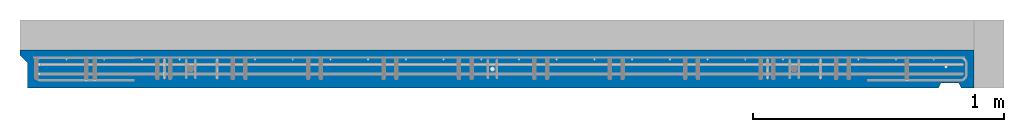
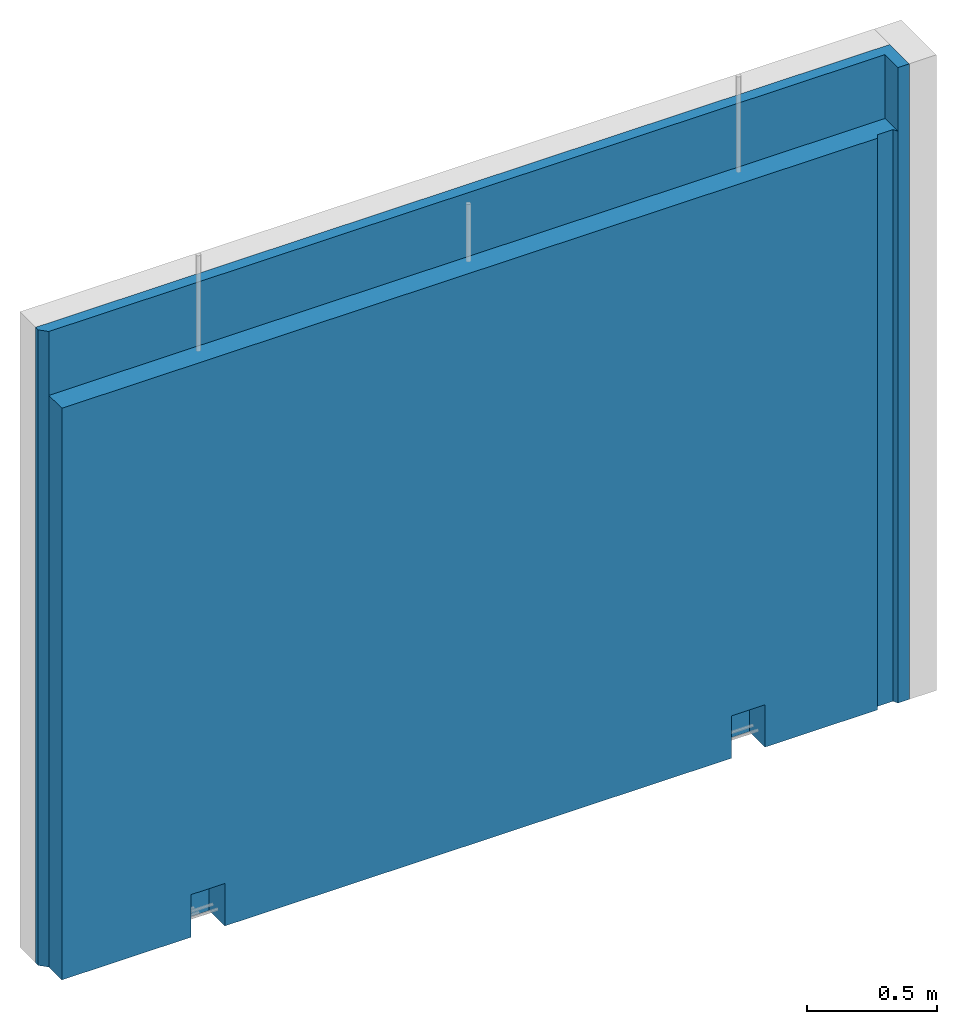
# One storey, part 9 of 9: 1 wall, 1 element without a shape of its own.
"""IFC2X3 building model written with IfcOpenShell, lengths in millimetres."""

from ifc_helpers import new_model, si_unit, frame, origin_with_axes, place, context, subcontext, project, spatial, faceted_brep, material, type_object, element, aggregate, save


model = new_model("IFC2X3")

# Units and contexts
model_context = context("Model", 3, precision=1e-05, world=origin_with_axes())
body_context = subcontext(model_context, "Body", "Model", "MODEL_VIEW")
ifc_project = project(units=[si_unit("LENGTHUNIT", "METRE", prefix="MILLI"), si_unit("AREAUNIT", "SQUARE_METRE"), si_unit("VOLUMEUNIT", "CUBIC_METRE"), si_unit("MASSUNIT", "GRAM", prefix="KILO"), si_unit("TIMEUNIT", "SECOND"), si_unit("PLANEANGLEUNIT", "RADIAN"), si_unit("SOLIDANGLEUNIT", "STERADIAN"), si_unit("THERMODYNAMICTEMPERATUREUNIT", "DEGREE_CELSIUS"), si_unit("LUMINOUSINTENSITYUNIT", "LUMEN")], contexts=[model_context])

# Site, building, storey
site_placement = place(None, origin_with_axes())
site = spatial("IfcSite", under=ifc_project, at=site_placement, CompositionType="ELEMENT")
building_placement = place(site_placement, origin_with_axes())
building = spatial("IfcBuilding", under=site, at=building_placement, Name="1", CompositionType="ELEMENT")
storey_placement = place(building_placement, origin_with_axes())
storey = spatial("IfcBuildingStorey", under=building, at=storey_placement, Name="1. kerros", CompositionType="ELEMENT", Elevation=0.0)

# Assembly, wall
assembly_placement = place(storey_placement, origin_with_axes())
assembly = element("IfcElementAssembly", 1, at=assembly_placement, inside=storey, AssemblyPlace="NOTDEFINED", PredefinedType="REINFORCEMENT_UNIT")
ifc_material = material(Name="CONCRETE/C30/37")
wall_type = type_object("IfcWallType", Name="2985X150", PredefinedType="NOTDEFINED")
wall_placement = place(assembly_placement, frame((41470.0022627602, 6575.00033187657, 1492.49992151562), z_axis=(0.0, 0.0, 1.0), x_axis=(0.999999999544916, -3.01690000137153e-05, 0.0)))
wall = element("IfcWall", 2, at=wall_placement, type_object=wall_type, material=ifc_material, ObjectType="2985X150", context=body_context, shape_type="Brep", body=[
    faceted_brep([(3654.40125343294, -75.0000001560766, 1192.49999998025), (3654.40125343294, -75.0, -1492.5), (3664.40125343294, -54.9932071461599, -1492.49999999915), (3664.40125343294, -54.9932071461599, 1192.49999998025), (3734.40125343294, -54.9932071461608, -1492.49999999915), (3734.40125343294, -54.9932071461608, 1192.49999998025), (3744.40125343294, -74.9932071458334, 1192.49999998025), (3744.40125343294, -75.0000000000009, -1492.5), (3154.07930080994, 45.0450785005714, -1492.51090734813), (3154.07930080994, 45.0450785005714, -1343.32355724257), (3004.07930079172, 45.0452070505726, -1343.32355724257), (3004.07930079172, 45.0452070505726, -1492.51090734732), (3154.07919796995, -74.9999999999991, -1492.5), (3154.07919796994, -74.954921499384, -1293.32355708434), (3004.07919795172, -74.9547929493838, -1293.32355708434), (3004.07919795173, -75.0, -1492.5), (754.079426868993, 45.0171910031831, -1492.54627628753), (754.079426868993, 45.0171910031831, -1342.54627644571), (604.079426850229, 45.0173195531843, -1342.54627644571), (604.079426850229, 45.0173195531843, -1492.54627628753), (754.079324028986, -75.0, -1492.5), (754.079324028993, -74.9828089967723, -1292.54627628753), (604.079324010228, -74.982680446773, -1292.54627628753), (604.079324010221, -75.0, -1492.5), (3744.40330902698, 24.999999840079, 1492.49999998025), (3744.40330902699, -75.0, 1492.5), (3794.40330907149, -75.0, 1492.5), (3794.4033090715, 75.0, 1492.5), (0.0, 74.9999999999991, 1492.5), (0.0, 54.9999999999054, 1492.5), (29.9999999712527, 24.9999999999054, 1492.5), (3794.40330907149, -75.0, -1492.5), (3794.4033090715, 75.0, -1492.5), (0.0, 74.9999999999991, -1492.5), (0.0, 54.9999999999054, -1492.5), (29.9999999712527, 24.9999998400781, 1192.49999998025), (29.9999999712527, 24.9999999999054, -1492.5), (29.9999999712527, -75.0000000000009, -1492.5), (29.9999999712527, -75.0000000012815, 1192.49999998025), (3744.40330902698, 24.999999840079, 1192.49999998025)], [[[0, 1, 2, 3]], [[3, 2, 4, 5]], [[6, 5, 4, 7]], [[8, 9, 10, 11]], [[12, 13, 9, 8]], [[14, 10, 9, 13]], [[11, 10, 14, 15]], [[16, 17, 18, 19]], [[20, 21, 17, 16]], [[22, 18, 17, 21]], [[19, 18, 22, 23]], [[24, 25, 26, 27, 28, 29, 30]], [[26, 31, 32, 27]], [[33, 28, 27, 32]], [[28, 33, 34, 29]], [[35, 36, 37, 38]], [[30, 29, 34, 36, 35]], [[39, 24, 30, 35]], [[24, 39, 6, 25]], [[31, 26, 25, 6, 7]], [[2, 1, 12, 8, 11, 15, 20, 16, 19, 23, 37, 36, 34, 33, 32, 31, 7, 4]], [[38, 37, 23, 22, 21, 20, 15, 14, 13, 12, 1, 0]], [[39, 35, 38, 0, 3, 5, 6]]]),
])
aggregate(assembly, [wall])

save(model, "model.ifc")
